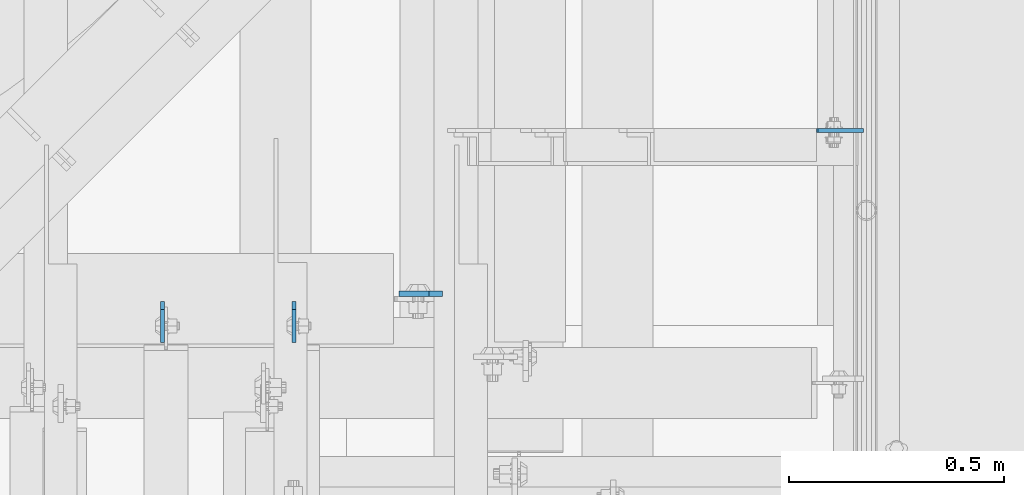
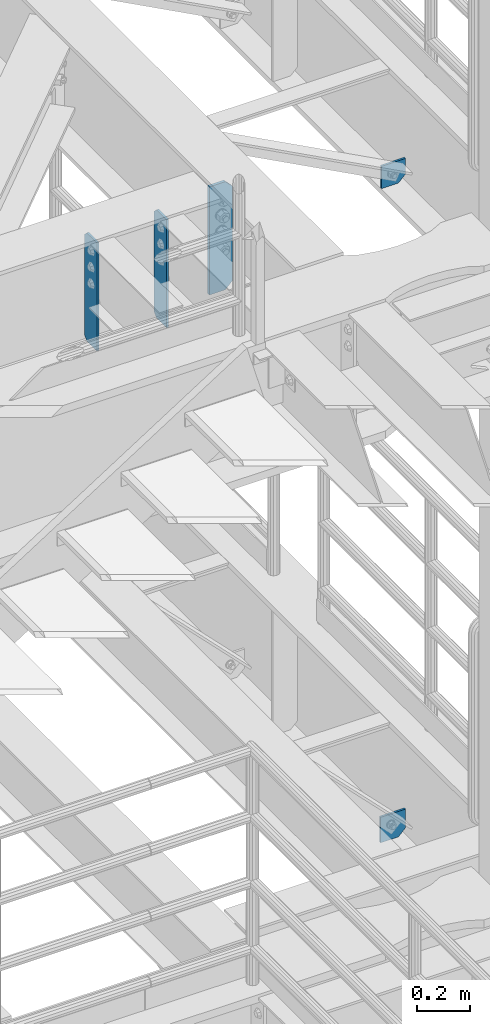
# One storey, part 1511 of 1876: 5 plates, 4 elements without a shape of their own.
"""IFC2X3 building model written with IfcOpenShell, lengths in millimetres."""

from ifc_helpers import new_model, si_unit, frame, origin_with_axes, place, context, subcontext, project, spatial, faceted_brep, material, type_object, element, aggregate, save


model = new_model("IFC2X3")

# Units and contexts
model_context = context("Model", 3, precision=1e-05, world=origin_with_axes())
body_context = subcontext(model_context, "Body", "Model", "MODEL_VIEW")
ifc_project = project(units=[si_unit("LENGTHUNIT", "METRE", prefix="MILLI"), si_unit("AREAUNIT", "SQUARE_METRE"), si_unit("VOLUMEUNIT", "CUBIC_METRE"), si_unit("MASSUNIT", "GRAM", prefix="KILO"), si_unit("TIMEUNIT", "SECOND"), si_unit("PLANEANGLEUNIT", "RADIAN"), si_unit("SOLIDANGLEUNIT", "STERADIAN"), si_unit("THERMODYNAMICTEMPERATUREUNIT", "DEGREE_CELSIUS"), si_unit("LUMINOUSINTENSITYUNIT", "LUMEN")], contexts=[model_context])

# Site, building, storey
site_placement = place(None, origin_with_axes())
site = spatial("IfcSite", under=ifc_project, at=site_placement, CompositionType="ELEMENT")
building_placement = place(site_placement, origin_with_axes())
building = spatial("IfcBuilding", under=site, at=building_placement, Name="Undefined", CompositionType="ELEMENT")
storey_placement = place(building_placement, origin_with_axes())
storey = spatial("IfcBuildingStorey", under=building, at=storey_placement, Name="Undefined", CompositionType="ELEMENT", Elevation=0.0)

# Assembly, plates
assembly_1_placement = place(storey_placement, origin_with_axes())
assembly_1 = element("IfcElementAssembly", 1, at=assembly_1_placement, inside=storey, Name="BEAM", AssemblyPlace="NOTDEFINED", PredefinedType="RIGID_FRAME")
ifc_material = material(Name="STEEL/A36")
plate_type_1 = type_object("IfcPlateType", PredefinedType="NOTDEFINED")
plate_1_placement = place(assembly_1_placement, frame((6291.26200006929, -3753.64375, 7635.875), z_axis=(0.0, 0.0, 1.0), x_axis=(0.0, -1.0, 0.0)))
plate_1 = element("IfcPlate", 2, at=plate_1_placement, type_object=plate_type_1, material=ifc_material, Name="PLATE", context=body_context, shape_type="Brep", body=[
    faceted_brep([(0.0, -4.76249999999982, 19.0499992370605), (0.0, -4.76249999999982, 481.012500762939), (0.0, 4.76249999999982, 481.012500762939), (0.0, 4.76249999999982, 19.0499992370605), (19.0499992370605, -4.76249999999982, 500.0625), (19.0499992370605, 4.76249999999982, 500.0625), (95.25, -4.76249999999982, 500.0625), (95.25, 4.76249999999982, 500.0625), (95.25, -4.76249999999982, 0.0), (95.25, 4.76249999999982, 0.0), (19.0499992370605, -4.76249999999982, 0.0), (19.0499992370605, 4.76249999999982, 0.0)], [[[0, 1, 2, 3]], [[1, 4, 5, 2]], [[4, 6, 7, 5]], [[6, 8, 9, 7]], [[8, 10, 11, 9]], [[10, 0, 3, 11]], [[5, 7, 9, 11, 3, 2]], [[10, 8, 6, 4, 1, 0]]]),
])
plate_2_placement = place(assembly_1_placement, frame((5986.46200006928, -3753.64375, 7635.875), z_axis=(0.0, 0.0, 1.0), x_axis=(0.0, -1.0, 0.0)))
plate_2 = element("IfcPlate", 3, at=plate_2_placement, type_object=plate_type_1, material=ifc_material, Name="PLATE", context=body_context, shape_type="Brep", body=[
    faceted_brep([(0.0, -4.76249999999982, 19.0499992370605), (0.0, -4.76249999999982, 481.012500762939), (0.0, 4.76249999999982, 481.012500762939), (0.0, 4.76249999999982, 19.0499992370605), (19.0499992370605, -4.76249999999982, 500.0625), (19.0499992370605, 4.76249999999982, 500.0625), (95.25, -4.76249999999982, 500.0625), (95.25, 4.76249999999982, 500.0625), (95.25, -4.76249999999982, 0.0), (95.25, 4.76249999999982, 0.0), (19.0499992370605, -4.76249999999982, 0.0), (19.0499992370605, 4.76249999999982, 0.0)], [[[0, 1, 2, 3]], [[1, 4, 5, 2]], [[4, 6, 7, 5]], [[6, 8, 9, 7]], [[8, 10, 11, 9]], [[10, 0, 3, 11]], [[5, 7, 9, 11, 3, 2]], [[10, 8, 6, 4, 1, 0]]]),
])
aggregate(assembly_1, [plate_1, plate_2])

# Assembly, plate
assembly_2_placement = place(storey_placement, origin_with_axes())
assembly_2 = element("IfcElementAssembly", 4, at=assembly_2_placement, inside=storey, Name="BEAM", AssemblyPlace="NOTDEFINED", PredefinedType="RIGID_FRAME")
plate_type_2 = type_object("IfcPlateType", PredefinedType="NOTDEFINED")
plate_3_placement = place(assembly_2_placement, frame((6636.54374997612, -3736.18124990463, 7635.875), z_axis=(0.0, 0.0, 1.0), x_axis=(-1.0, 0.0, 0.0)))
plate_3 = element("IfcPlate", 5, at=plate_3_placement, type_object=plate_type_2, material=ifc_material, Name="PLATE", context=body_context, shape_type="Brep", body=[
    faceted_brep([(0.0, -6.34999999999991, 31.75), (0.0, -6.34999999999991, 468.3125), (0.0, 6.34999999999991, 468.3125), (0.0, 6.34999999999991, 31.75), (31.75, -6.34999999999991, 500.0625), (31.75, 6.34999999999991, 500.0625), (101.599998474121, -6.34999999999991, 500.0625), (101.599998474121, 6.34999999999991, 500.0625), (101.599998474121, -6.35000000000036, 0.0), (101.599998474121, 6.35000000000036, 0.0), (31.75, -6.34999999999991, 0.0), (31.75, 6.34999999999991, 0.0)], [[[0, 1, 2, 3]], [[1, 4, 5, 2]], [[4, 6, 7, 5]], [[6, 8, 9, 7]], [[8, 10, 11, 9]], [[10, 0, 3, 11]], [[5, 7, 9, 11, 3, 2]], [[10, 8, 6, 4, 1, 0]]]),
])
aggregate(assembly_2, [plate_3])

assembly_3_placement = place(storey_placement, origin_with_axes())
assembly_3 = element("IfcElementAssembly", 6, at=assembly_3_placement, inside=storey, Name="BEAM", AssemblyPlace="NOTDEFINED", PredefinedType="RIGID_FRAME")
plate_type_3 = type_object("IfcPlateType", PredefinedType="NOTDEFINED")
plate_4_placement = place(assembly_3_placement, frame((7503.65051543112, -3357.5625, 4533.9), z_axis=(0.0, 0.0, 1.0), x_axis=(1.0, 0.0, 0.0)))
plate_4 = element("IfcPlate", 7, at=plate_4_placement, type_object=plate_type_3, material=ifc_material, Name="PLATE", context=body_context, shape_type="Brep", body=[
    faceted_brep([(0.0, -4.76249999999982, 0.0), (0.0, -4.76249999999982, 118.153335571289), (0.0, 4.76249999999982, 118.153335571289), (0.0, 4.76249999999982, 0.0), (109.20573425293, -4.76249999999982, 118.153335571289), (109.20573425293, 4.76249999999982, 118.153335571289), (109.20573425293, -4.76249999999982, 31.75), (109.20573425293, 4.76249999999982, 31.75), (77.4557342529297, -4.76249999999982, 0.0), (77.4557342529297, 4.76249999999982, 0.0)], [[[0, 1, 2, 3]], [[1, 4, 5, 2]], [[4, 6, 7, 5]], [[6, 8, 9, 7]], [[8, 0, 3, 9]], [[5, 7, 9, 3, 2]], [[8, 6, 4, 1, 0]]]),
])
aggregate(assembly_3, [plate_4])

assembly_4_placement = place(storey_placement, origin_with_axes())
assembly_4 = element("IfcElementAssembly", 8, at=assembly_4_placement, inside=storey, Name="BEAM", AssemblyPlace="NOTDEFINED", PredefinedType="RIGID_FRAME")
plate_type_4 = type_object("IfcPlateType", PredefinedType="NOTDEFINED")
plate_5_placement = place(assembly_4_placement, frame((7507.5353264326, -3357.5625, 7556.5), z_axis=(0.0, 0.0, 1.0), x_axis=(1.0, 0.0, 0.0)))
plate_5 = element("IfcPlate", 9, at=plate_5_placement, type_object=plate_type_4, material=ifc_material, Name="PLATE", context=body_context, shape_type="Brep", body=[
    faceted_brep([(0.0, -4.76249999999982, 0.0), (0.0, -4.76249999999999, 103.538208007812), (0.0, 4.76249999999999, 103.538208007812), (0.0, 4.76249999999982, 0.0), (105.320922851562, -4.76249999999999, 103.538208007812), (105.320922851562, 4.76249999999999, 103.538208007812), (105.320922851562, -4.76249999999999, 31.75), (105.320922851562, 4.76249999999999, 31.75), (73.5709228515625, -4.76249999999999, 0.0), (73.5709228515625, 4.76249999999999, 0.0)], [[[0, 1, 2, 3]], [[1, 4, 5, 2]], [[4, 6, 7, 5]], [[6, 8, 9, 7]], [[8, 0, 3, 9]], [[5, 7, 9, 3, 2]], [[8, 6, 4, 1, 0]]]),
])
aggregate(assembly_4, [plate_5])

save(model, "model.ifc")
